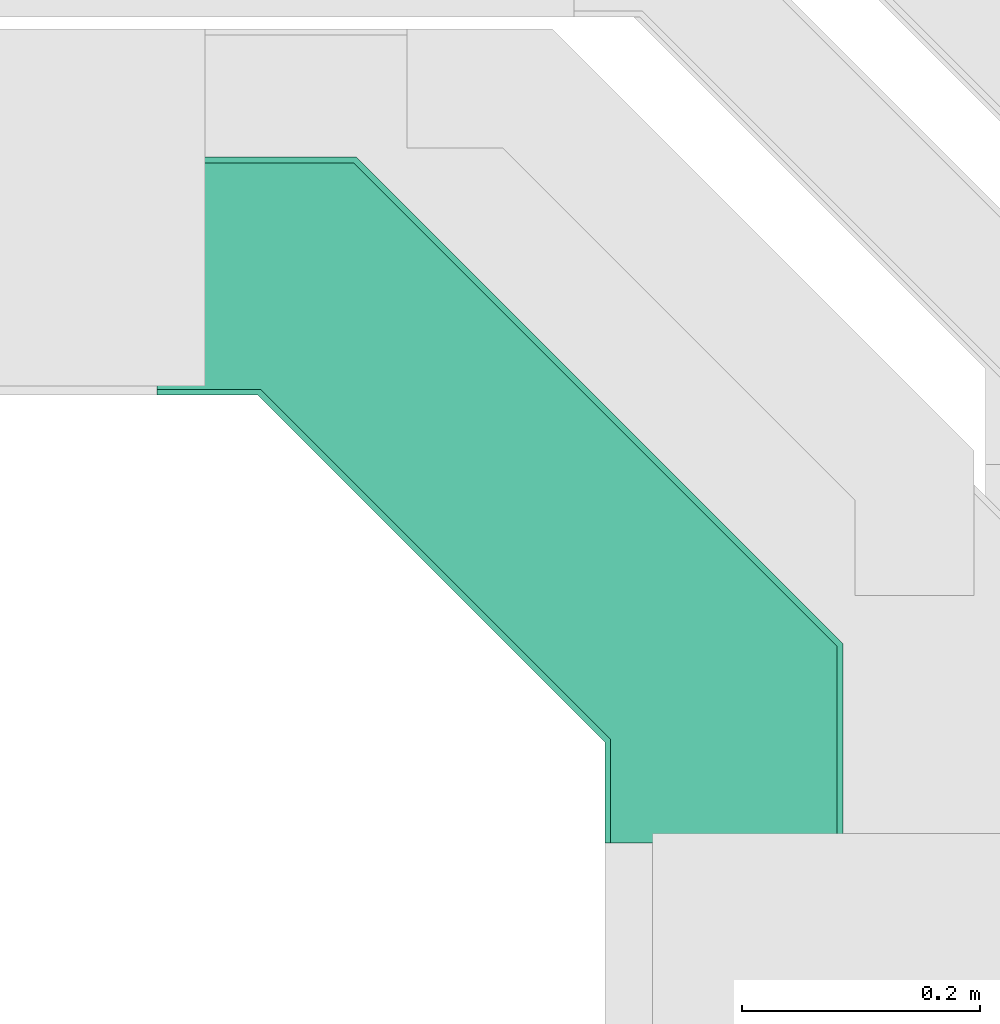
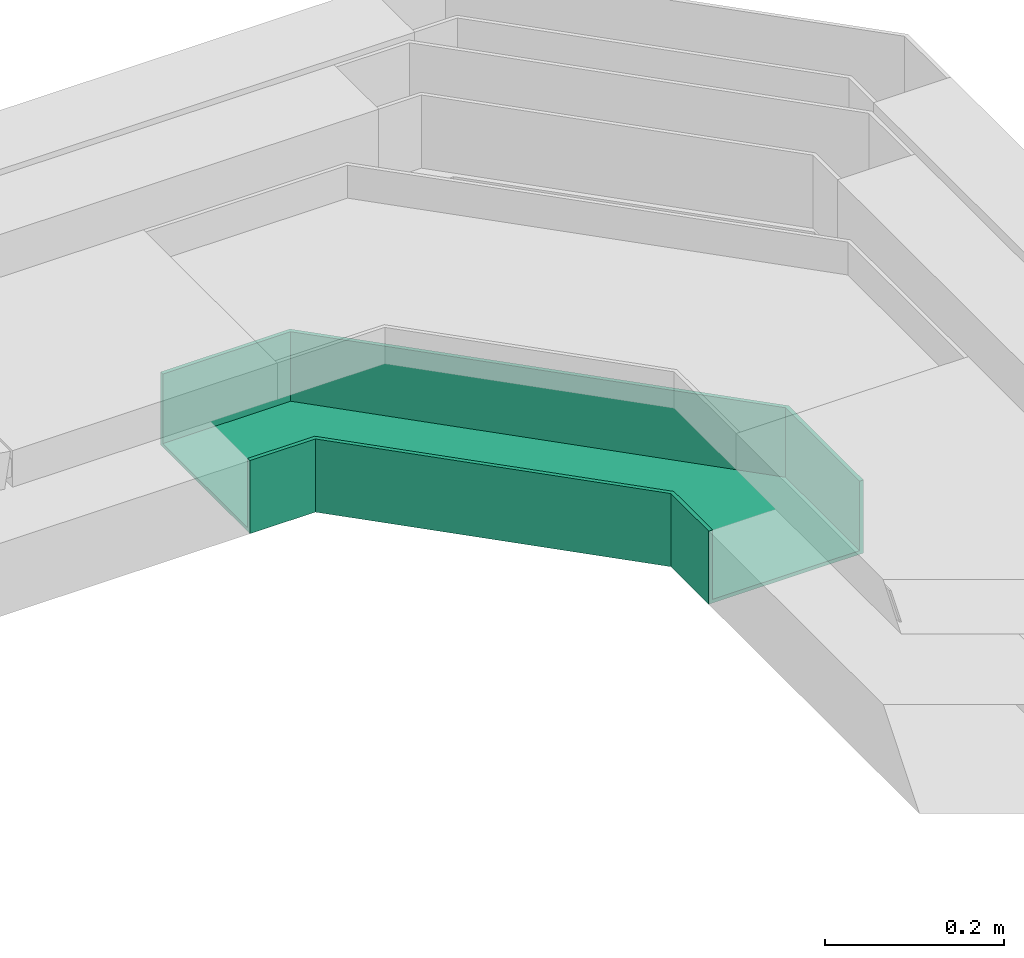
# One storey, part 33 of 33: 1 flow fitting.
"""IFC2X3 building model written with IfcOpenShell, lengths in millimetres."""

from ifc_helpers import new_model, entity, si_unit, converted_unit, derived_unit, direction, frame, origin, place, context, subcontext, project, spatial, faceted_brep, source, transform, mapped, material, type_object, type_shapes, element, save


model = new_model("IFC2X3")

# Units and contexts
model_context = context("Model", 3, precision=0.01, world=origin(), true_north=direction((6.12303176911189e-17, 1.0)))
body_context = subcontext(model_context, "Body", "Model", "MODEL_VIEW")
ifc_project = project(units=[si_unit("LENGTHUNIT", "METRE", prefix="MILLI"), si_unit("AREAUNIT", "SQUARE_METRE"), si_unit("VOLUMEUNIT", "CUBIC_METRE"), converted_unit("PLANEANGLEUNIT", "DEGREE", entity("IfcRatioMeasure", 0.0174532925199433), si_unit("PLANEANGLEUNIT", "RADIAN"), dimensions=[0, 0, 0, 0, 0, 0, 0]), si_unit("MASSUNIT", "GRAM", prefix="KILO"), derived_unit("MASSDENSITYUNIT", [(si_unit("MASSUNIT", "GRAM", prefix="KILO"), 1), (si_unit("LENGTHUNIT", "METRE"), -3)]), derived_unit("MOMENTOFINERTIAUNIT", [(si_unit("LENGTHUNIT", "METRE"), 4)]), si_unit("TIMEUNIT", "SECOND"), si_unit("FREQUENCYUNIT", "HERTZ"), si_unit("THERMODYNAMICTEMPERATUREUNIT", "DEGREE_CELSIUS"), derived_unit("THERMALTRANSMITTANCEUNIT", [(si_unit("MASSUNIT", "GRAM", prefix="KILO"), 1), (si_unit("THERMODYNAMICTEMPERATUREUNIT", "KELVIN"), -1), (si_unit("TIMEUNIT", "SECOND"), -3)]), derived_unit("VOLUMETRICFLOWRATEUNIT", [(si_unit("LENGTHUNIT", "METRE"), 3), (si_unit("TIMEUNIT", "SECOND"), -1)]), derived_unit("MASSFLOWRATEUNIT", [(si_unit("MASSUNIT", "GRAM", prefix="KILO"), 1), (si_unit("TIMEUNIT", "SECOND"), -1)]), derived_unit("ROTATIONALFREQUENCYUNIT", [(si_unit("TIMEUNIT", "SECOND"), -1)]), si_unit("ELECTRICCURRENTUNIT", "AMPERE"), si_unit("ELECTRICVOLTAGEUNIT", "VOLT"), si_unit("POWERUNIT", "WATT"), si_unit("FORCEUNIT", "NEWTON", prefix="KILO"), si_unit("ILLUMINANCEUNIT", "LUX"), si_unit("LUMINOUSFLUXUNIT", "LUMEN"), si_unit("LUMINOUSINTENSITYUNIT", "CANDELA"), derived_unit("USERDEFINED", [(si_unit("MASSUNIT", "GRAM", prefix="KILO"), -1), (si_unit("LENGTHUNIT", "METRE"), -2), (si_unit("TIMEUNIT", "SECOND"), 3), (si_unit("LUMINOUSFLUXUNIT", "LUMEN"), 1)]), derived_unit("LINEARVELOCITYUNIT", [(si_unit("LENGTHUNIT", "METRE"), 1), (si_unit("TIMEUNIT", "SECOND"), -1)]), si_unit("PRESSUREUNIT", "PASCAL"), derived_unit("USERDEFINED", [(si_unit("LENGTHUNIT", "METRE"), -2), (si_unit("MASSUNIT", "GRAM", prefix="KILO"), 1), (si_unit("TIMEUNIT", "SECOND"), -2)]), derived_unit("LINEARFORCEUNIT", [(si_unit("MASSUNIT", "GRAM", prefix="KILO"), 1), (si_unit("LENGTHUNIT", "METRE"), 1), (si_unit("TIMEUNIT", "SECOND"), -2), (si_unit("LENGTHUNIT", "METRE"), -1)]), derived_unit("PLANARFORCEUNIT", [(si_unit("MASSUNIT", "GRAM", prefix="KILO"), 1), (si_unit("LENGTHUNIT", "METRE"), 1), (si_unit("TIMEUNIT", "SECOND"), -2), (si_unit("LENGTHUNIT", "METRE"), -2)])], contexts=[model_context])

# Site, building, storey
site_placement = place(None, frame((0.0, -0.00077364408347762, 0.0)))
site = spatial("IfcSite", under=ifc_project, at=site_placement, CompositionType="ELEMENT")
building_placement = place(site_placement, origin())
building = spatial("IfcBuilding", under=site, at=building_placement, CompositionType="ELEMENT")
storey_placement = place(building_placement, frame((0.0, 0.0, 8100.0)))
storey = spatial("IfcBuildingStorey", under=building, at=storey_placement, CompositionType="ELEMENT", Elevation=8100.0)

# Flow fitting
ifc_material = material()
cable_carrier_fitting_type = type_object("IfcCableCarrierFittingType", Name="470_DKC_G5_Sheet horizontal bend:-", PredefinedType="NOTDEFINED", material=ifc_material)
shared_shape = source(origin(), body_context, "Body", "Brep", [
    faceted_brep([(-476.0, -100.0, -50.0), (-476.0, -100.0, 50.0), (-476.0, -95.0, 50.0), (-476.0, -95.0, -45.0), (-476.0, 95.0, -45.0), (-476.0, 95.0, 50.0), (-476.0, 100.0, 50.0), (-476.0, 100.0, -50.0), (100.0, 476.0, -50.0), (-100.0, 476.0, -50.0), (-100.0, 476.0, 50.0), (-95.0, 476.0, 50.0), (-95.0, 476.0, -45.0), (95.0, 476.0, -45.0), (95.0, 476.0, 50.0), (100.0, 476.0, 50.0), (-308.578643762682, -100.0, -50.0), (-308.578643762682, -100.0, 50.0), (100.0, 308.578643762679, 50.0), (95.0, 310.649711574545, 50.0), (-310.649711574548, -95.0, 50.0), (-310.649711574548, -95.0, -45.0), (95.0, 310.649711574545, -45.0), (-95.0, 389.350288425433, -45.0), (-389.350288425436, 95.0, -45.0), (-389.350288425436, 95.0, 50.0), (-95.0, 389.350288425433, 50.0), (-100.0, 391.421356237299, 50.0), (-391.421356237301, 100.0, 50.0), (-391.421356237301, 100.0, -50.0), (-100.0, 391.421356237298, -50.0), (100.0, 308.57864376268, -50.0)], [[[0, 1, 2, 3, 4, 5, 6, 7]], [[8, 9, 10, 11, 12, 13, 14, 15]], [[1, 0, 16, 17]], [[2, 1, 17, 18, 15, 14, 19, 20]], [[3, 2, 20, 21]], [[4, 3, 21, 22, 13, 12, 23, 24]], [[5, 4, 24, 25]], [[6, 5, 25, 26, 11, 10, 27, 28]], [[7, 6, 28, 29]], [[0, 7, 29, 30, 9, 8, 31, 16]], [[17, 16, 31, 18]], [[21, 20, 19, 22]], [[25, 24, 23, 26]], [[29, 28, 27, 30]], [[18, 31, 8, 15]], [[22, 19, 14, 13]], [[26, 23, 12, 11]], [[30, 27, 10, 9]]]),
])
type_shapes(cable_carrier_fitting_type, [shared_shape])
flow_fitting_placement = place(storey_placement, frame((60360.1085349486, 14274.4992263554, 2599.99985619669), z_axis=(4.13853607338931e-08, -3.23835000490124e-05, 1.0), x_axis=(0.0, 1.0, 3.23835000490124e-05)))
element("IfcFlowFitting", 1, at=flow_fitting_placement, inside=storey, type_object=cable_carrier_fitting_type, material=ifc_material, Name="470_DKC_G5_Sheet horizontal bend:-", ObjectType="470_DKC_G5_Sheet horizontal bend:-", context=body_context, shape_type="MappedRepresentation", body=[
    mapped(shared_shape, transform((0.0, 0.0, 0.0), scale=1.0)),
])

save(model, "model.ifc")
